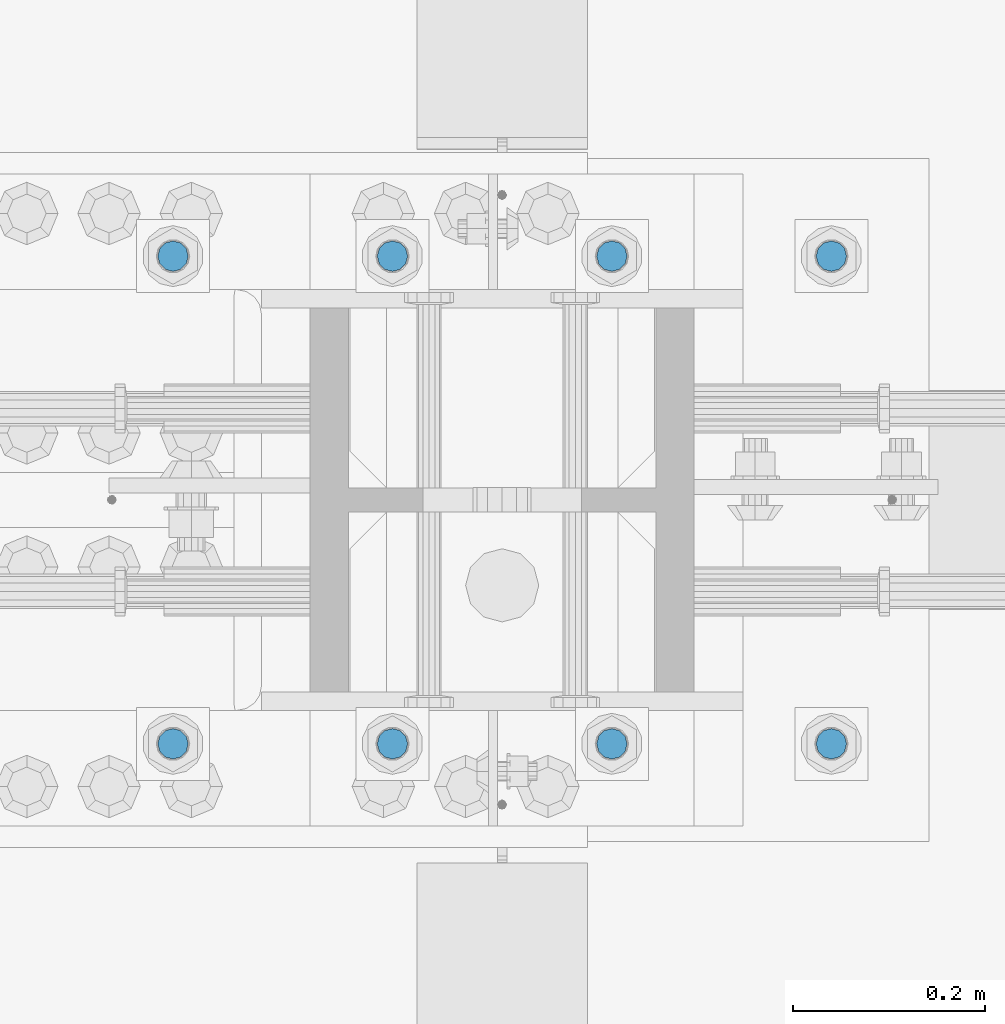
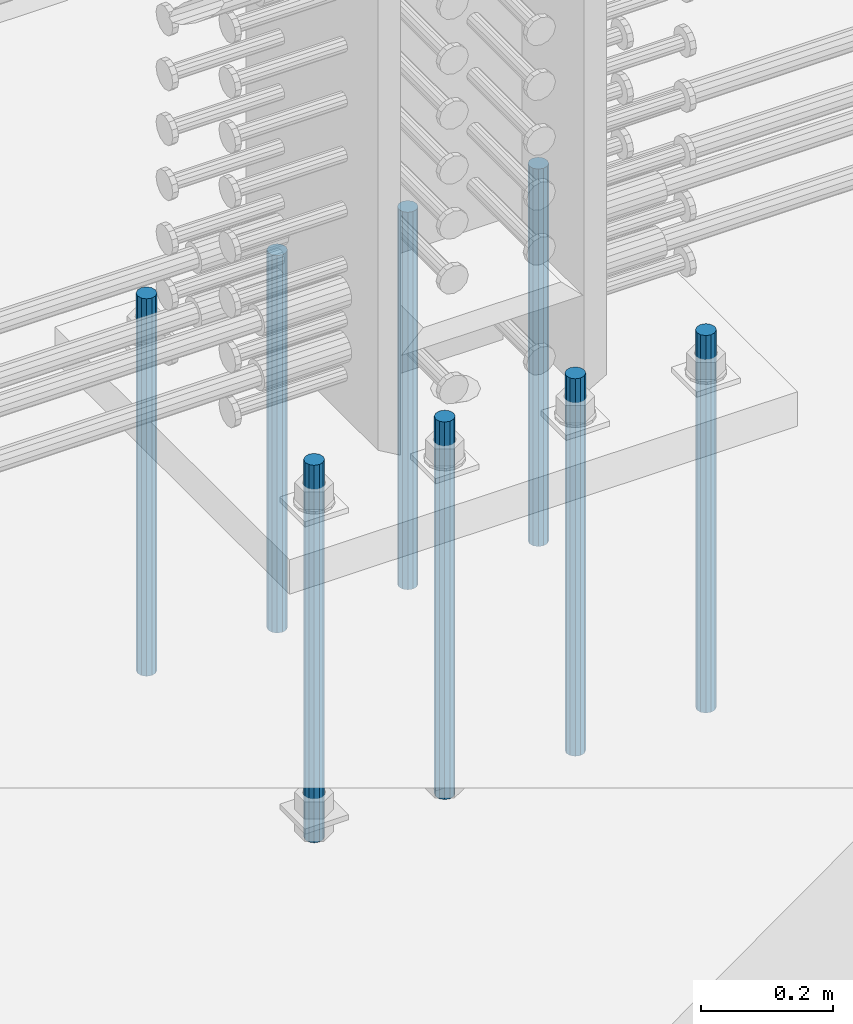
# One storey, part 935 of 1763: 8 columns, 1 element without a shape of its own.
"""IFC2X3 building model written with IfcOpenShell, lengths in millimetres."""

from ifc_helpers import new_model, si_unit, frame, origin_with_axes, place, context, subcontext, project, spatial, faceted_brep, material, type_object, element, aggregate, save


model = new_model("IFC2X3")

# Units and contexts
model_context = context("Model", 3, precision=1e-05, world=origin_with_axes())
body_context = subcontext(model_context, "Body", "Model", "MODEL_VIEW")
ifc_project = project(units=[si_unit("LENGTHUNIT", "METRE", prefix="MILLI"), si_unit("AREAUNIT", "SQUARE_METRE"), si_unit("VOLUMEUNIT", "CUBIC_METRE"), si_unit("MASSUNIT", "GRAM", prefix="KILO"), si_unit("TIMEUNIT", "SECOND"), si_unit("PLANEANGLEUNIT", "RADIAN"), si_unit("SOLIDANGLEUNIT", "STERADIAN"), si_unit("THERMODYNAMICTEMPERATUREUNIT", "DEGREE_CELSIUS"), si_unit("LUMINOUSINTENSITYUNIT", "LUMEN")], contexts=[model_context])

# Site, building, storey
site_placement = place(None, origin_with_axes())
site = spatial("IfcSite", under=ifc_project, at=site_placement, CompositionType="ELEMENT")
building_placement = place(site_placement, origin_with_axes())
building = spatial("IfcBuilding", under=site, at=building_placement, Name="Undefined", CompositionType="ELEMENT")
storey_placement = place(building_placement, origin_with_axes())
storey = spatial("IfcBuildingStorey", under=building, at=storey_placement, Name="Undefined", CompositionType="ELEMENT", Elevation=0.0)

# Assembly, columns
assembly_placement = place(storey_placement, origin_with_axes())
assembly = element("IfcElementAssembly", 1, at=assembly_placement, inside=storey, Name="TEMPLATE", AssemblyPlace="NOTDEFINED", PredefinedType="RIGID_FRAME")
ifc_material = material()
column_type = type_object("IfcColumnType", PredefinedType="NOTDEFINED")
column_1_placement = place(assembly_placement, frame((-34606.937273698, 203.199999999951, 4000.5), z_axis=(1.0, 0.0, 0.0), x_axis=(0.0, 0.0, -1.0)))
column_1 = element("IfcColumn", 2, at=column_1_placement, type_object=column_type, material=ifc_material, Name="ALL THREADED ROD", context=body_context, shape_type="Brep", body=[
    faceted_brep([(0.0, -15.875, 0.0), (0.0, -13.7481532850798, -7.9375), (698.499, -13.7481532850798, -7.9375), (698.499, -15.875, 0.0), (0.0, -7.9375, -13.748153285078), (698.499, -7.9375, -13.748153285078), (4.91792532185561e-12, 0.0, -15.875), (698.499, 0.0, -15.875), (0.0, 7.9375, -13.748153285078), (698.499, 7.9375, -13.748153285078), (0.0, 13.7481532850798, -7.9375), (698.499, 13.7481532850798, -7.9375), (0.0, 15.875, 0.0), (698.499, 15.875, 0.0), (0.0, 13.7481532850798, 7.9375), (698.499, 13.7481532850798, 7.9375), (0.0, 7.9375, 13.748153285078), (698.499, 7.9375, 13.748153285078), (-1.64518337079051e-12, 0.0, 15.875), (698.499, 0.0, 15.875), (0.0, -7.9375, 13.748153285078), (698.499, -7.9375, 13.748153285078), (0.0, -13.7481532850798, 7.9375), (698.499, -13.7481532850798, 7.9375)], [[[0, 1, 2, 3]], [[1, 4, 5, 2]], [[4, 6, 7, 5]], [[6, 8, 9, 7]], [[8, 10, 11, 9]], [[10, 12, 13, 11]], [[12, 14, 15, 13]], [[14, 16, 17, 15]], [[16, 18, 19, 17]], [[18, 20, 21, 19]], [[20, 22, 23, 21]], [[22, 0, 3, 23]], [[5, 7, 9, 11, 13, 15, 17, 19, 21, 23, 3, 2]], [[22, 20, 18, 16, 14, 12, 10, 8, 6, 4, 1, 0]]]),
])
column_2_placement = place(assembly_placement, frame((-34606.937273698, 711.199999999951, 4000.5), z_axis=(-1.0, 0.0, 0.0), x_axis=(0.0, 0.0, -1.0)))
column_2 = element("IfcColumn", 3, at=column_2_placement, type_object=column_type, material=ifc_material, Name="ALL THREADED ROD", context=body_context, shape_type="Brep", body=[
    faceted_brep([(0.0, -15.875, 0.0), (0.0, -13.7481532850798, -7.9375), (698.499, -13.7481532850798, -7.9375), (698.499, -15.875, 0.0), (0.0, -7.9375, -13.748153285078), (698.499, -7.9375, -13.748153285078), (4.91792532185561e-12, 0.0, -15.875), (698.499, 0.0, -15.875), (0.0, 7.9375, -13.748153285078), (698.499, 7.9375, -13.748153285078), (0.0, 13.7481532850798, -7.9375), (698.499, 13.7481532850798, -7.9375), (0.0, 15.875, 0.0), (698.499, 15.875, 0.0), (0.0, 13.7481532850798, 7.9375), (698.499, 13.7481532850798, 7.9375), (0.0, 7.9375, 13.748153285078), (698.499, 7.9375, 13.748153285078), (-1.64518337079051e-12, 0.0, 15.875), (698.499, 0.0, 15.875), (0.0, -7.9375, 13.748153285078), (698.499, -7.9375, 13.748153285078), (0.0, -13.7481532850798, 7.9375), (698.499, -13.7481532850798, 7.9375)], [[[0, 1, 2, 3]], [[1, 4, 5, 2]], [[4, 6, 7, 5]], [[6, 8, 9, 7]], [[8, 10, 11, 9]], [[10, 12, 13, 11]], [[12, 14, 15, 13]], [[14, 16, 17, 15]], [[16, 18, 19, 17]], [[18, 20, 21, 19]], [[20, 22, 23, 21]], [[22, 0, 3, 23]], [[5, 7, 9, 11, 13, 15, 17, 19, 21, 23, 3, 2]], [[22, 20, 18, 16, 14, 12, 10, 8, 6, 4, 1, 0]]]),
])
column_3_placement = place(assembly_placement, frame((-34835.537273698, 203.199999999951, 4000.5), z_axis=(1.0, 0.0, 0.0), x_axis=(0.0, 0.0, -1.0)))
column_3 = element("IfcColumn", 4, at=column_3_placement, type_object=column_type, material=ifc_material, Name="ALL THREADED ROD", context=body_context, shape_type="Brep", body=[
    faceted_brep([(0.0, -15.875, 0.0), (0.0, -13.7481532850798, -7.9375), (698.499, -13.7481532850798, -7.9375), (698.499, -15.875, 0.0), (0.0, -7.9375, -13.748153285078), (698.499, -7.9375, -13.748153285078), (4.91792532185561e-12, 0.0, -15.875), (698.499, 0.0, -15.875), (0.0, 7.9375, -13.748153285078), (698.499, 7.9375, -13.748153285078), (0.0, 13.7481532850798, -7.9375), (698.499, 13.7481532850798, -7.9375), (0.0, 15.875, 0.0), (698.499, 15.875, 0.0), (0.0, 13.7481532850798, 7.9375), (698.499, 13.7481532850798, 7.9375), (0.0, 7.9375, 13.748153285078), (698.499, 7.9375, 13.748153285078), (-1.64518337079051e-12, 0.0, 15.875), (698.499, 0.0, 15.875), (0.0, -7.9375, 13.748153285078), (698.499, -7.9375, 13.748153285078), (0.0, -13.7481532850798, 7.9375), (698.499, -13.7481532850798, 7.9375)], [[[0, 1, 2, 3]], [[1, 4, 5, 2]], [[4, 6, 7, 5]], [[6, 8, 9, 7]], [[8, 10, 11, 9]], [[10, 12, 13, 11]], [[12, 14, 15, 13]], [[14, 16, 17, 15]], [[16, 18, 19, 17]], [[18, 20, 21, 19]], [[20, 22, 23, 21]], [[22, 0, 3, 23]], [[5, 7, 9, 11, 13, 15, 17, 19, 21, 23, 3, 2]], [[22, 20, 18, 16, 14, 12, 10, 8, 6, 4, 1, 0]]]),
])
column_4_placement = place(assembly_placement, frame((-34835.537273698, 711.199999999951, 4000.5), z_axis=(-1.0, 0.0, 0.0), x_axis=(0.0, 0.0, -1.0)))
column_4 = element("IfcColumn", 5, at=column_4_placement, type_object=column_type, material=ifc_material, Name="ALL THREADED ROD", context=body_context, shape_type="Brep", body=[
    faceted_brep([(0.0, -15.875, 0.0), (0.0, -13.7481532850798, -7.9375), (698.499, -13.7481532850798, -7.9375), (698.499, -15.875, 0.0), (0.0, -7.9375, -13.748153285078), (698.499, -7.9375, -13.748153285078), (4.91792532185561e-12, 0.0, -15.875), (698.499, 0.0, -15.875), (0.0, 7.9375, -13.748153285078), (698.499, 7.9375, -13.748153285078), (0.0, 13.7481532850798, -7.9375), (698.499, 13.7481532850798, -7.9375), (0.0, 15.875, 0.0), (698.499, 15.875, 0.0), (0.0, 13.7481532850798, 7.9375), (698.499, 13.7481532850798, 7.9375), (0.0, 7.9375, 13.748153285078), (698.499, 7.9375, 13.748153285078), (-1.64518337079051e-12, 0.0, 15.875), (698.499, 0.0, 15.875), (0.0, -7.9375, 13.748153285078), (698.499, -7.9375, 13.748153285078), (0.0, -13.7481532850798, 7.9375), (698.499, -13.7481532850798, 7.9375)], [[[0, 1, 2, 3]], [[1, 4, 5, 2]], [[4, 6, 7, 5]], [[6, 8, 9, 7]], [[8, 10, 11, 9]], [[10, 12, 13, 11]], [[12, 14, 15, 13]], [[14, 16, 17, 15]], [[16, 18, 19, 17]], [[18, 20, 21, 19]], [[20, 22, 23, 21]], [[22, 0, 3, 23]], [[5, 7, 9, 11, 13, 15, 17, 19, 21, 23, 3, 2]], [[22, 20, 18, 16, 14, 12, 10, 8, 6, 4, 1, 0]]]),
])
column_5_placement = place(assembly_placement, frame((-35064.137273698, 203.199999999951, 4000.5), z_axis=(1.0, 0.0, 0.0), x_axis=(0.0, 0.0, -1.0)))
column_5 = element("IfcColumn", 6, at=column_5_placement, type_object=column_type, material=ifc_material, Name="ALL THREADED ROD", context=body_context, shape_type="Brep", body=[
    faceted_brep([(0.0, -15.875, 0.0), (0.0, -13.7481532850798, -7.9375), (698.499, -13.7481532850798, -7.9375), (698.499, -15.875, 0.0), (0.0, -7.9375, -13.748153285078), (698.499, -7.9375, -13.748153285078), (4.91792532185561e-12, 0.0, -15.875), (698.499, 0.0, -15.875), (0.0, 7.9375, -13.748153285078), (698.499, 7.9375, -13.748153285078), (0.0, 13.7481532850798, -7.9375), (698.499, 13.7481532850798, -7.9375), (0.0, 15.875, 0.0), (698.499, 15.875, 0.0), (0.0, 13.7481532850798, 7.9375), (698.499, 13.7481532850798, 7.9375), (0.0, 7.9375, 13.748153285078), (698.499, 7.9375, 13.748153285078), (-1.64518337079051e-12, 0.0, 15.875), (698.499, 0.0, 15.875), (0.0, -7.9375, 13.748153285078), (698.499, -7.9375, 13.748153285078), (0.0, -13.7481532850798, 7.9375), (698.499, -13.7481532850798, 7.9375)], [[[0, 1, 2, 3]], [[1, 4, 5, 2]], [[4, 6, 7, 5]], [[6, 8, 9, 7]], [[8, 10, 11, 9]], [[10, 12, 13, 11]], [[12, 14, 15, 13]], [[14, 16, 17, 15]], [[16, 18, 19, 17]], [[18, 20, 21, 19]], [[20, 22, 23, 21]], [[22, 0, 3, 23]], [[5, 7, 9, 11, 13, 15, 17, 19, 21, 23, 3, 2]], [[22, 20, 18, 16, 14, 12, 10, 8, 6, 4, 1, 0]]]),
])
column_6_placement = place(assembly_placement, frame((-35064.137273698, 711.199999999951, 4000.5), z_axis=(-1.0, 0.0, 0.0), x_axis=(0.0, 0.0, -1.0)))
column_6 = element("IfcColumn", 7, at=column_6_placement, type_object=column_type, material=ifc_material, Name="ALL THREADED ROD", context=body_context, shape_type="Brep", body=[
    faceted_brep([(0.0, -15.875, 0.0), (0.0, -13.7481532850798, -7.9375), (698.499, -13.7481532850798, -7.9375), (698.499, -15.875, 0.0), (0.0, -7.9375, -13.748153285078), (698.499, -7.9375, -13.748153285078), (4.91792532185561e-12, 0.0, -15.875), (698.499, 0.0, -15.875), (0.0, 7.9375, -13.748153285078), (698.499, 7.9375, -13.748153285078), (0.0, 13.7481532850798, -7.9375), (698.499, 13.7481532850798, -7.9375), (0.0, 15.875, 0.0), (698.499, 15.875, 0.0), (0.0, 13.7481532850798, 7.9375), (698.499, 13.7481532850798, 7.9375), (0.0, 7.9375, 13.748153285078), (698.499, 7.9375, 13.748153285078), (-1.64518337079051e-12, 0.0, 15.875), (698.499, 0.0, 15.875), (0.0, -7.9375, 13.748153285078), (698.499, -7.9375, 13.748153285078), (0.0, -13.7481532850798, 7.9375), (698.499, -13.7481532850798, 7.9375)], [[[0, 1, 2, 3]], [[1, 4, 5, 2]], [[4, 6, 7, 5]], [[6, 8, 9, 7]], [[8, 10, 11, 9]], [[10, 12, 13, 11]], [[12, 14, 15, 13]], [[14, 16, 17, 15]], [[16, 18, 19, 17]], [[18, 20, 21, 19]], [[20, 22, 23, 21]], [[22, 0, 3, 23]], [[5, 7, 9, 11, 13, 15, 17, 19, 21, 23, 3, 2]], [[22, 20, 18, 16, 14, 12, 10, 8, 6, 4, 1, 0]]]),
])
column_7_placement = place(assembly_placement, frame((-35292.737273698, 203.199999999951, 4000.5), z_axis=(1.0, 0.0, 0.0), x_axis=(0.0, 0.0, -1.0)))
column_7 = element("IfcColumn", 8, at=column_7_placement, type_object=column_type, material=ifc_material, Name="ALL THREADED ROD", context=body_context, shape_type="Brep", body=[
    faceted_brep([(0.0, -15.875, 0.0), (0.0, -13.7481532850798, -7.9375), (698.499, -13.7481532850798, -7.9375), (698.499, -15.875, 0.0), (0.0, -7.9375, -13.748153285078), (698.499, -7.9375, -13.748153285078), (4.91792532185561e-12, 0.0, -15.875), (698.499, 0.0, -15.875), (0.0, 7.9375, -13.748153285078), (698.499, 7.9375, -13.748153285078), (0.0, 13.7481532850798, -7.9375), (698.499, 13.7481532850798, -7.9375), (0.0, 15.875, 0.0), (698.499, 15.875, 0.0), (0.0, 13.7481532850798, 7.9375), (698.499, 13.7481532850798, 7.9375), (0.0, 7.9375, 13.748153285078), (698.499, 7.9375, 13.748153285078), (-1.64518337079051e-12, 0.0, 15.875), (698.499, 0.0, 15.875), (0.0, -7.9375, 13.748153285078), (698.499, -7.9375, 13.748153285078), (0.0, -13.7481532850798, 7.9375), (698.499, -13.7481532850798, 7.9375)], [[[0, 1, 2, 3]], [[1, 4, 5, 2]], [[4, 6, 7, 5]], [[6, 8, 9, 7]], [[8, 10, 11, 9]], [[10, 12, 13, 11]], [[12, 14, 15, 13]], [[14, 16, 17, 15]], [[16, 18, 19, 17]], [[18, 20, 21, 19]], [[20, 22, 23, 21]], [[22, 0, 3, 23]], [[5, 7, 9, 11, 13, 15, 17, 19, 21, 23, 3, 2]], [[22, 20, 18, 16, 14, 12, 10, 8, 6, 4, 1, 0]]]),
])
column_8_placement = place(assembly_placement, frame((-35292.737273698, 711.199999999951, 4000.5), z_axis=(-1.0, 0.0, 0.0), x_axis=(0.0, 0.0, -1.0)))
column_8 = element("IfcColumn", 9, at=column_8_placement, type_object=column_type, material=ifc_material, Name="ALL THREADED ROD", context=body_context, shape_type="Brep", body=[
    faceted_brep([(0.0, -15.875, 0.0), (0.0, -13.7481532850798, -7.9375), (698.499, -13.7481532850798, -7.9375), (698.499, -15.875, 0.0), (0.0, -7.9375, -13.748153285078), (698.499, -7.9375, -13.748153285078), (4.91792532185561e-12, 0.0, -15.875), (698.499, 0.0, -15.875), (0.0, 7.9375, -13.748153285078), (698.499, 7.9375, -13.748153285078), (0.0, 13.7481532850798, -7.9375), (698.499, 13.7481532850798, -7.9375), (0.0, 15.875, 0.0), (698.499, 15.875, 0.0), (0.0, 13.7481532850798, 7.9375), (698.499, 13.7481532850798, 7.9375), (0.0, 7.9375, 13.748153285078), (698.499, 7.9375, 13.748153285078), (-1.64518337079051e-12, 0.0, 15.875), (698.499, 0.0, 15.875), (0.0, -7.9375, 13.748153285078), (698.499, -7.9375, 13.748153285078), (0.0, -13.7481532850798, 7.9375), (698.499, -13.7481532850798, 7.9375)], [[[0, 1, 2, 3]], [[1, 4, 5, 2]], [[4, 6, 7, 5]], [[6, 8, 9, 7]], [[8, 10, 11, 9]], [[10, 12, 13, 11]], [[12, 14, 15, 13]], [[14, 16, 17, 15]], [[16, 18, 19, 17]], [[18, 20, 21, 19]], [[20, 22, 23, 21]], [[22, 0, 3, 23]], [[5, 7, 9, 11, 13, 15, 17, 19, 21, 23, 3, 2]], [[22, 20, 18, 16, 14, 12, 10, 8, 6, 4, 1, 0]]]),
])
aggregate(assembly, [column_1, column_2, column_3, column_4, column_5, column_6, column_7, column_8])

save(model, "model.ifc")
